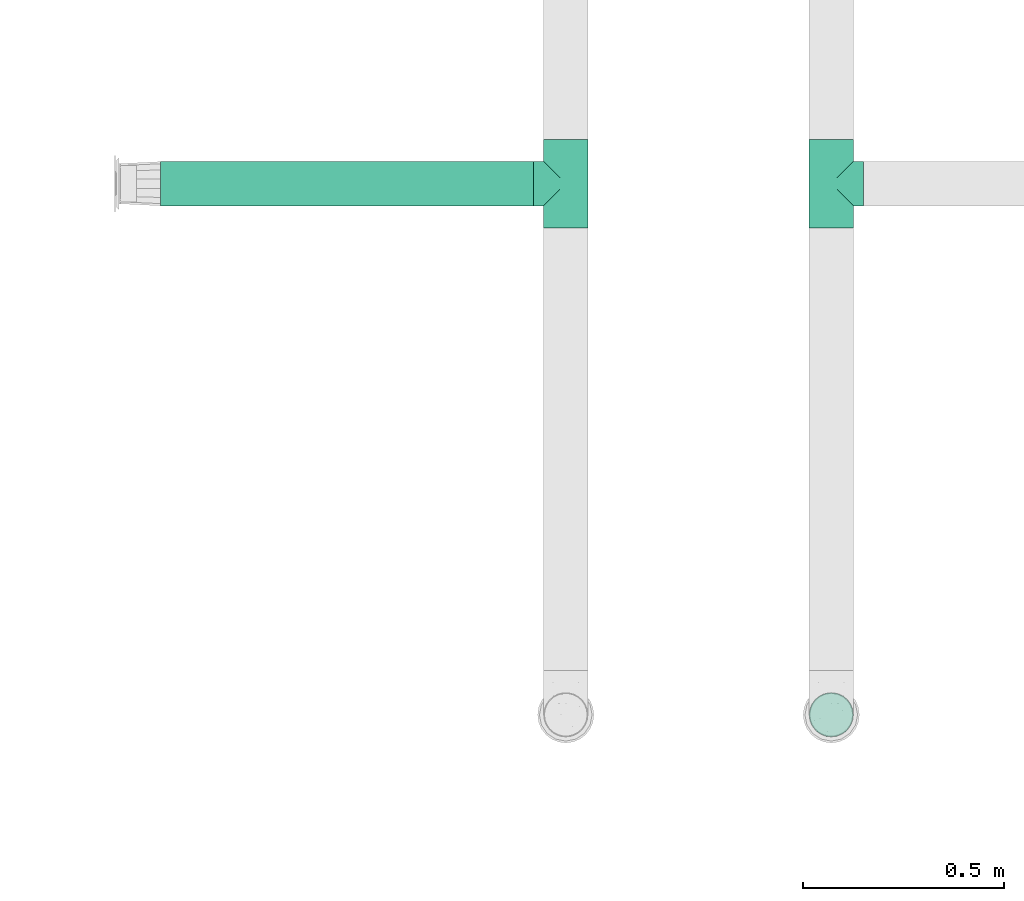
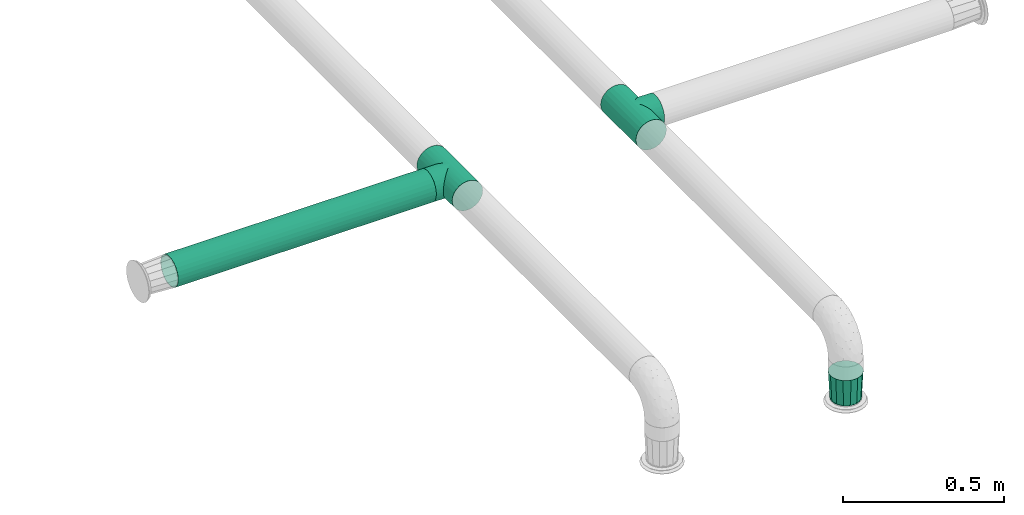
# One storey, part 50 of 115: 3 flow fittings, 1 flow segment.
"""IFC2X3 building model written with IfcOpenShell, lengths in millimetres."""

from ifc_helpers import new_model, entity, si_unit, converted_unit, derived_unit, direction, frame, origin_with_axes, origin_2d_with_axis, place, context, subcontext, project, spatial, hollow_circle, extrude, open_shell, surface_model, source, transform, mapped, material, layer, layer_set, layer_usage, type_object, element, save


model = new_model("IFC2X3")

# Units and contexts
model_context = context("Model", 3, precision=1e-05, world=origin_with_axes(), true_north=direction((0.0, 1.0)))
body_context = subcontext(model_context, "Body", "Model", "MODEL_VIEW")
ifc_project = project(units=[si_unit("AREAUNIT", "SQUARE_METRE"), si_unit("VOLUMEUNIT", "CUBIC_METRE", prefix="DECI"), si_unit("TIMEUNIT", "SECOND"), si_unit("THERMODYNAMICTEMPERATUREUNIT", "DEGREE_CELSIUS"), si_unit("PRESSUREUNIT", "PASCAL"), si_unit("MASSUNIT", "GRAM", prefix="KILO"), si_unit("LENGTHUNIT", "METRE", prefix="MILLI"), si_unit("POWERUNIT", "WATT"), si_unit("ELECTRICCURRENTUNIT", "AMPERE"), si_unit("ELECTRICVOLTAGEUNIT", "VOLT"), derived_unit("VOLUMETRICFLOWRATEUNIT", [(si_unit("VOLUMEUNIT", "CUBIC_METRE", prefix="DECI"), 1), (si_unit("TIMEUNIT", "SECOND"), -1)]), derived_unit("LINEARVELOCITYUNIT", [(si_unit("LENGTHUNIT", "METRE"), 1), (si_unit("TIMEUNIT", "SECOND"), -1)]), derived_unit("MASSDENSITYUNIT", [(si_unit("MASSUNIT", "GRAM", prefix="KILO"), 1), (si_unit("VOLUMEUNIT", "CUBIC_METRE"), -1)]), converted_unit("PLANEANGLEUNIT", "DEGREE", entity("IfcRatioMeasure", 0.01745), si_unit("PLANEANGLEUNIT", "RADIAN"), dimensions=[0, 0, 0, 0, 0, 0, 0])], contexts=[model_context])

# Site, building, storey
site_placement = place(None, origin_with_axes())
site = spatial("IfcSite", under=ifc_project, at=site_placement, CompositionType="ELEMENT")
building_placement = place(site_placement, origin_with_axes())
building = spatial("IfcBuilding", under=site, at=building_placement, Name="mc-building", CompositionType="ELEMENT")
storey_placement = place(building_placement, frame((0.0, 0.0, 2950.0), z_axis=(0.0, 0.0, 1.0), x_axis=(1.0, 0.0, 0.0)))
storey = spatial("IfcBuildingStorey", under=building, at=storey_placement, Name="2. Korrus", CompositionType="ELEMENT", Elevation=2950.0)

# Flow fittings
duct_fitting_type_1 = type_object("IfcDuctFittingType", PredefinedType="JUNCTION")
shared_shape_1 = source(origin_with_axes(), body_context, "Body", "SurfaceModel", [
    surface_model("IfcShellBasedSurfaceModel", [(0.0, -80.0, -55.0), (14.23505, -80.0, -53.12592), (-14.23505, -80.0, -53.12592), (-53.12592, -80.0, 14.23505), (-27.5, -80.0, -47.63139), (-47.63139, -80.0, -27.5), (-38.89087, -80.0, -38.89087), (55.0, -80.0, 0.0), (53.12592, -80.0, 14.23505), (38.89087, -80.0, -38.89087), (27.5, -80.0, -47.63139), (53.12592, -80.0, -14.23505), (47.63139, -80.0, -27.5), (-53.12592, -80.0, -14.23505), (-47.63139, -80.0, 27.5), (-38.89087, -80.0, 38.89087), (14.23505, -80.0, 53.12592), (-27.5, -80.0, 47.63139), (-14.23505, -80.0, 53.12592), (47.63139, -80.0, 27.5), (38.89087, -80.0, 38.89087), (27.5, -80.0, 47.63139), (0.0, -80.0, 55.0), (-55.0, -80.0, 0.0), (0.0, 0.0, 55.0), (-7.4066, -7.4066, 54.49901), (-14.74521, -14.74521, 52.98659), (-21.93978, -21.93978, 50.43457), (-28.89905, -28.89905, 46.79578), (-35.50357, -35.50357, 42.00591), (-41.58668, -41.58668, 35.99373), (-46.92319, -46.92319, 28.69171), (-51.19777, -51.19777, 20.0945), (-50.37866, -80.0, 20.86752), (-54.01174, -54.01174, 10.37938), (-55.0, -55.0, 0.0), (-54.06296, -80.0, 7.11752), (-54.01174, -54.01174, -10.37938), (-51.19777, -51.19777, -20.0945), (-54.06296, -80.0, -7.11752), (-46.92319, -46.92319, -28.69171), (-41.58668, -41.58668, -35.99373), (-50.37866, -80.0, -20.86752), (-35.50357, -35.50357, -42.00591), (-21.93978, -21.93978, -50.43457), (-14.74521, -14.74521, -52.98659), (-7.4066, -7.4066, -54.49901), (0.0, 0.0, -55.0), (-28.89905, -28.89905, -46.79578), (7.4066, -7.4066, -54.49901), (14.74521, -14.74521, -52.98659), (21.93978, -21.93978, -50.43457), (28.89905, -28.89905, -46.79578), (35.50357, -35.50357, -42.00591), (41.58668, -41.58668, -35.99373), (46.92319, -46.92319, -28.69171), (51.19777, -51.19777, -20.0945), (50.37866, -80.0, -20.86752), (54.01174, -54.01174, -10.37938), (55.0, -55.0, 0.0), (54.06296, -80.0, -7.11752), (54.01174, -54.01174, 10.37938), (51.19777, -51.19777, 20.0945), (54.06296, -80.0, 7.11752), (46.92319, -46.92319, 28.69171), (41.58668, -41.58668, 35.99373), (50.37866, -80.0, 20.86752), (35.50357, -35.50357, 42.00591), (21.93978, -21.93978, 50.43457), (14.74521, -14.74521, 52.98659), (7.4066, -7.4066, 54.49901), (28.89905, -28.89905, 46.79578), (-110.0, 0.0, -55.0), (-110.0, -14.23505, -53.12592), (-110.0, 14.23505, -53.12592), (-110.0, 53.12592, 14.23505), (-110.0, 27.5, -47.63139), (-110.0, 47.63139, -27.5), (-110.0, 38.89087, -38.89087), (-110.0, -55.0, 0.0), (-110.0, -53.12592, 14.23505), (-110.0, -38.89087, -38.89087), (-110.0, -27.5, -47.63139), (-110.0, -53.12592, -14.23505), (-110.0, -47.63139, -27.5), (-110.0, 53.12592, -14.23505), (-110.0, 47.63139, 27.5), (-110.0, 38.89087, 38.89087), (-110.0, -14.23505, 53.12592), (-110.0, 27.5, 47.63139), (-110.0, 14.23505, 53.12592), (-110.0, -47.63139, 27.5), (-110.0, -38.89087, 38.89087), (-110.0, -27.5, 47.63139), (-110.0, 0.0, 55.0), (-110.0, 55.0, 0.0), (110.0, 55.0, 0.0), (110.0, 0.0, -55.0), (110.0, 14.23505, -53.12592), (110.0, 27.5, -47.63139), (110.0, 38.89087, -38.89087), (110.0, 47.63139, -27.5), (110.0, -38.89087, -38.89087), (110.0, -53.12592, 14.23505), (110.0, -27.5, -47.63139), (110.0, -14.23505, -53.12592), (110.0, -47.63139, -27.5), (110.0, -53.12592, -14.23505), (110.0, -55.0, 0.0), (110.0, 53.12592, -14.23505), (110.0, 53.12592, 14.23505), (110.0, 47.63139, 27.5), (110.0, 38.89087, 38.89087), (110.0, 0.0, 55.0), (110.0, 27.5, 47.63139), (110.0, 14.23505, 53.12592), (110.0, -47.63139, 27.5), (110.0, -38.89087, 38.89087), (110.0, -27.5, 47.63139), (110.0, -14.23505, 53.12592)], [open_shell([[[0, 1, 2]], [[2, 3, 4]], [[5, 6, 3]], [[6, 4, 3]], [[2, 7, 8]], [[9, 7, 10]], [[1, 10, 7]], [[11, 7, 12]], [[9, 12, 7]], [[7, 2, 1]], [[5, 3, 13]], [[2, 14, 3]], [[2, 15, 14]], [[2, 16, 17]], [[17, 15, 2]], [[16, 18, 17]], [[2, 8, 19]], [[2, 19, 20]], [[2, 20, 21]], [[16, 2, 21]], [[16, 22, 18]], [[23, 13, 3]], [[24, 25, 22]], [[26, 27, 18]], [[25, 26, 18]], [[22, 25, 18]], [[17, 28, 29]], [[17, 18, 27]], [[17, 29, 15]], [[28, 17, 27]], [[30, 31, 14]], [[32, 3, 33]], [[32, 34, 3]], [[35, 36, 34]], [[31, 32, 14]], [[15, 30, 14]], [[34, 36, 3]], [[33, 14, 32]], [[36, 35, 23]], [[30, 15, 29]], [[37, 38, 13]], [[37, 13, 39]], [[40, 41, 5]], [[38, 5, 42]], [[38, 40, 5]], [[37, 39, 35]], [[35, 39, 23]], [[13, 38, 42]], [[41, 6, 5]], [[41, 43, 6]], [[44, 45, 2]], [[46, 47, 0]], [[45, 46, 2]], [[43, 48, 4]], [[44, 4, 48]], [[44, 2, 4]], [[46, 0, 2]], [[43, 4, 6]], [[47, 49, 0]], [[50, 51, 1]], [[49, 50, 1]], [[0, 49, 1]], [[10, 52, 53]], [[10, 1, 51]], [[10, 53, 9]], [[52, 10, 51]], [[54, 55, 12]], [[56, 11, 57]], [[56, 58, 11]], [[59, 60, 58]], [[55, 56, 12]], [[9, 54, 12]], [[58, 60, 11]], [[57, 12, 56]], [[60, 59, 7]], [[54, 9, 53]], [[61, 62, 8]], [[61, 8, 63]], [[64, 65, 19]], [[62, 19, 66]], [[62, 64, 19]], [[61, 63, 59]], [[7, 59, 63]], [[62, 66, 8]], [[65, 20, 19]], [[65, 67, 20]], [[68, 69, 16]], [[70, 24, 22]], [[69, 70, 16]], [[67, 71, 21]], [[68, 21, 71]], [[68, 16, 21]], [[70, 22, 16]], [[67, 21, 20]], [[72, 73, 74]], [[74, 75, 76]], [[77, 78, 75]], [[76, 75, 78]], [[74, 79, 80]], [[81, 79, 82]], [[73, 82, 79]], [[83, 79, 84]], [[81, 84, 79]], [[79, 74, 73]], [[77, 75, 85]], [[74, 86, 75]], [[74, 87, 86]], [[74, 88, 89]], [[89, 87, 74]], [[88, 90, 89]], [[74, 91, 92]], [[91, 74, 80]], [[92, 93, 74]], [[74, 93, 88]], [[88, 94, 90]], [[95, 85, 75]], [[96, 97, 98]], [[99, 96, 98]], [[96, 100, 101]], [[100, 96, 99]], [[102, 97, 103]], [[97, 102, 104]], [[104, 105, 97]], [[102, 103, 106]], [[106, 103, 107]], [[108, 107, 103]], [[109, 96, 101]], [[110, 111, 97]], [[97, 111, 112]], [[113, 97, 114]], [[97, 112, 114]], [[113, 114, 115]], [[116, 103, 97]], [[117, 116, 97]], [[118, 117, 97]], [[119, 118, 97]], [[119, 97, 113]], [[96, 110, 97]], [[24, 113, 115]], [[89, 115, 114]], [[94, 24, 90]], [[90, 24, 115]], [[115, 89, 90]], [[114, 87, 89]], [[86, 112, 111]], [[75, 111, 110]], [[95, 110, 96]], [[87, 112, 86]], [[86, 111, 75]], [[110, 95, 75]], [[112, 87, 114]], [[85, 96, 109]], [[77, 109, 101]], [[95, 96, 85]], [[85, 109, 77]], [[101, 78, 77]], [[101, 100, 78]], [[76, 100, 99]], [[74, 99, 98]], [[47, 98, 97]], [[76, 99, 74]], [[47, 72, 74]], [[98, 47, 74]], [[100, 76, 78]], [[47, 46, 72]], [[45, 44, 73]], [[46, 45, 73]], [[72, 46, 73]], [[82, 48, 43]], [[82, 73, 44]], [[82, 43, 81]], [[48, 82, 44]], [[41, 40, 84]], [[38, 37, 83]], [[40, 38, 84]], [[81, 41, 84]], [[37, 79, 83]], [[83, 84, 38]], [[79, 37, 35]], [[41, 81, 43]], [[49, 97, 105]], [[105, 104, 51]], [[53, 104, 102]], [[53, 52, 104]], [[49, 47, 97]], [[51, 50, 105]], [[52, 51, 104]], [[49, 105, 50]], [[54, 102, 106]], [[56, 106, 107]], [[58, 107, 108]], [[55, 54, 106]], [[58, 56, 107]], [[59, 58, 108]], [[55, 106, 56]], [[102, 54, 53]], [[34, 32, 80]], [[31, 30, 91]], [[32, 31, 91]], [[35, 34, 79]], [[80, 79, 34]], [[32, 91, 80]], [[30, 92, 91]], [[30, 29, 92]], [[27, 26, 88]], [[25, 24, 94]], [[26, 25, 88]], [[29, 28, 93]], [[27, 93, 28]], [[27, 88, 93]], [[25, 94, 88]], [[29, 93, 92]], [[61, 108, 103]], [[62, 103, 116]], [[65, 116, 117]], [[61, 59, 108]], [[64, 62, 116]], [[65, 64, 116]], [[61, 103, 62]], [[117, 67, 65]], [[71, 67, 118]], [[118, 67, 117]], [[68, 118, 119]], [[70, 119, 113]], [[68, 71, 118]], [[70, 69, 119]], [[24, 70, 113]], [[68, 119, 69]]])]),
])
flow_fitting_1_placement = place(storey_placement, frame((11458.64544, 9505.0, 2465.0), z_axis=(0.0, 0.0, 1.0), x_axis=(0.0, -1.0, 0.0)))
element("IfcFlowFitting", 1, at=flow_fitting_1_placement, inside=storey, type_object=duct_fitting_type_1, context=body_context, shape_type="MappedRepresentation", body=[
    mapped(shared_shape_1, transform((0.0, 0.0, 0.0), scale=1.0)),
])
duct_fitting_type_2 = type_object("IfcDuctFittingType", PredefinedType="TRANSITION")
shared_shape_2 = source(origin_with_axes(), body_context, "Body", "SurfaceModel", [
    surface_model("IfcShellBasedSurfaceModel", [(100.0, -55.0, 0.0), (100.0, -12.23865, 53.62104), (100.0, -34.29194, 43.00073), (100.0, 49.55329, 23.86361), (100.0, 34.29194, 43.00073), (100.0, 49.55329, -23.86361), (0.0, -45.04844, -21.69419), (0.0, -50.0, 0.0), (0.0, -45.04844, 21.69419), (0.0, 31.17449, 39.09157), (0.0, 45.04844, 21.69419), (0.0, 50.0, 0.0), (98.0, 47.63139, 27.5), (98.0, 0.0, 55.0), (98.0, 38.89087, 38.89087), (98.0, -38.89087, 38.89087), (98.0, -47.63139, 27.5), (100.0, 12.23865, 53.62104), (100.0, -49.55329, 23.86361), (100.0, 55.0, 0.0), (100.0, 12.23865, -53.62104), (100.0, 34.29194, -43.00073), (100.0, -49.55329, -23.86361), (100.0, -34.29194, -43.00073), (100.0, -12.23865, -53.62104), (0.0, -31.17449, 39.09157), (0.0, -11.12605, 48.7464), (0.0, 11.12605, 48.7464), (0.0, -31.17449, -39.09157), (0.0, 11.12605, -48.7464), (0.0, -11.12605, -48.7464), (0.0, 45.04844, -21.69419), (0.0, 31.17449, -39.09157), (0.0, 47.52422, -10.84709), (0.0, 38.11147, -30.39288), (100.0, 41.92261, -33.43217), (100.0, -41.92261, -33.43217), (0.0, -38.11147, -30.39288), (100.0, 23.2653, -48.31088), (0.0, 21.15027, -43.91899), (100.0, 52.32388, -11.72483), (0.0, 0.0, -48.7464), (100.0, 0.0, -53.62104), (0.0, -21.15027, -43.91899), (100.0, -23.2653, -48.31088), (0.0, -47.52422, -10.84709), (100.0, -52.32388, -11.72483), (0.0, -47.52422, 10.84709), (0.0, -38.11147, 30.39288), (100.0, -41.92261, 33.43217), (100.0, 41.92261, 33.43217), (0.0, 38.11147, 30.39288), (100.0, -23.2653, 48.31088), (0.0, -21.15027, 43.91899), (100.0, -52.32388, 11.72483), (0.0, 0.0, 48.7464), (100.0, 0.0, 53.62104), (0.0, 21.15027, 43.91899), (100.0, 23.2653, 48.31088), (0.0, 47.52422, 10.84709), (100.0, 52.32388, 11.72483), (100.0, -14.23505, -53.12592), (100.0, 0.0, -55.0), (100.0, -27.5, -47.63139), (100.0, 27.5, -47.63139), (100.0, -38.89087, -38.89087), (100.0, -53.12592, -14.23505), (100.0, -47.63139, -27.5), (100.0, -47.63139, 27.5), (100.0, 14.23505, -53.12592), (100.0, 38.89087, -38.89087), (100.0, 47.63139, -27.5), (100.0, 47.63139, 27.5), (100.0, 53.12592, -14.23505), (100.0, -53.12592, 14.23505), (100.0, -38.89087, 38.89087), (100.0, -27.5, 47.63139), (100.0, 0.0, 55.0), (100.0, -14.23505, 53.12592), (100.0, 53.12592, 14.23505), (100.0, 38.89087, 38.89087), (100.0, 27.5, 47.63139), (100.0, 14.23505, 53.12592), (98.0, -27.5, 47.63139), (98.0, -14.23505, 53.12592), (98.0, -53.12592, -14.23505), (98.0, 14.23505, 53.12592), (98.0, 27.5, 47.63139), (98.0, 53.12592, 14.23505), (98.0, 55.0, 0.0), (98.0, -47.63139, -27.5), (98.0, -53.12592, 14.23505), (98.0, 27.5, -47.63139), (98.0, -27.5, -47.63139), (98.0, -38.89087, -38.89087), (98.0, 0.0, -55.0), (98.0, -14.23505, -53.12592), (98.0, 38.89087, -38.89087), (98.0, 47.63139, -27.5), (98.0, 53.12592, -14.23505), (98.0, 14.23505, -53.12592), (98.0, -55.0, 0.0), (0.0, 0.0, 50.0), (0.0, 35.35534, 35.35534), (0.0, -12.94095, 48.29629), (0.0, -25.0, 43.30127), (0.0, -35.35534, 35.35534), (0.0, -48.29629, 12.94095), (0.0, -43.30127, 25.0), (0.0, 25.0, 43.30127), (0.0, 12.94095, 48.29629), (0.0, 43.30127, 25.0), (0.0, 48.29629, 12.94095), (0.0, 25.0, -43.30127), (0.0, 48.29629, -12.94095), (0.0, -48.29629, -12.94095), (0.0, -43.30127, -25.0), (0.0, -12.94095, -48.29629), (0.0, -25.0, -43.30127), (0.0, -35.35534, -35.35534), (0.0, 43.30127, -25.0), (0.0, 35.35534, -35.35534), (0.0, 12.94095, -48.29629), (0.0, 0.0, -50.0), (2.0, -35.35534, -35.35534), (2.0, -25.0, -43.30127), (2.0, -12.94095, -48.29629), (2.0, -43.30127, -25.0), (2.0, 0.0, -50.0), (2.0, -48.29629, -12.94095), (2.0, -50.0, 0.0), (2.0, 12.94095, -48.29629), (2.0, 25.0, -43.30127), (2.0, 43.30127, -25.0), (2.0, 48.29629, -12.94095), (2.0, 35.35534, -35.35534), (2.0, -48.29629, 12.94095), (2.0, -35.35534, 35.35534), (2.0, -43.30127, 25.0), (2.0, 35.35534, 35.35534), (2.0, -12.94095, 48.29629), (2.0, -25.0, 43.30127), (2.0, 0.0, 50.0), (2.0, 43.30127, 25.0), (2.0, 48.29629, 12.94095), (2.0, 50.0, 0.0), (2.0, 25.0, 43.30127), (2.0, 12.94095, 48.29629)], [open_shell([[[0, 1, 2]], [[3, 4, 5]], [[6, 7, 8]], [[9, 10, 11]], [[12, 13, 14]], [[15, 13, 16]], [[0, 4, 17]], [[2, 18, 0]], [[1, 0, 17]], [[3, 5, 19]], [[20, 21, 5]], [[22, 20, 5]], [[22, 5, 0]], [[22, 23, 24]], [[22, 24, 20]], [[4, 0, 5]], [[8, 25, 6]], [[6, 25, 26]], [[6, 26, 27]], [[11, 27, 9]], [[28, 6, 29]], [[30, 28, 29]], [[31, 6, 11]], [[31, 32, 29]], [[31, 29, 6]], [[27, 11, 6]], [[31, 33, 5]], [[34, 35, 32]], [[36, 22, 6]], [[36, 37, 23]], [[38, 29, 39]], [[33, 40, 5]], [[33, 11, 40]], [[19, 40, 11]], [[32, 21, 39]], [[32, 35, 21]], [[34, 31, 35]], [[30, 41, 42]], [[28, 43, 44]], [[42, 41, 20]], [[7, 45, 46]], [[38, 39, 21]], [[46, 0, 7]], [[6, 37, 36]], [[38, 20, 29]], [[43, 30, 24]], [[42, 24, 30]], [[28, 23, 37]], [[6, 22, 45]], [[35, 31, 5]], [[44, 43, 24]], [[20, 41, 29]], [[46, 45, 22]], [[44, 23, 28]], [[8, 47, 18]], [[48, 49, 25]], [[50, 3, 10]], [[50, 51, 4]], [[52, 26, 53]], [[47, 54, 18]], [[47, 7, 54]], [[0, 54, 7]], [[25, 2, 53]], [[25, 49, 2]], [[48, 8, 49]], [[27, 55, 56]], [[9, 57, 58]], [[56, 55, 1]], [[11, 59, 60]], [[52, 53, 2]], [[60, 19, 11]], [[10, 51, 50]], [[52, 1, 26]], [[57, 27, 17]], [[56, 17, 27]], [[9, 4, 51]], [[10, 3, 59]], [[49, 8, 18]], [[58, 57, 17]], [[1, 55, 26]], [[60, 59, 3]], [[58, 4, 9]], [[61, 62, 63]], [[63, 64, 65]], [[66, 67, 68]], [[65, 64, 67]], [[67, 64, 68]], [[69, 64, 62]], [[64, 63, 62]], [[70, 71, 64]], [[72, 64, 71]], [[71, 73, 19]], [[74, 0, 66]], [[72, 68, 64]], [[75, 68, 76]], [[77, 78, 76]], [[72, 76, 68]], [[76, 72, 77]], [[79, 72, 19]], [[19, 72, 71]], [[80, 81, 77]], [[77, 72, 80]], [[82, 77, 81]], [[74, 66, 68]], [[83, 84, 13]], [[15, 83, 13]], [[12, 16, 13]], [[16, 12, 85]], [[86, 87, 13]], [[87, 14, 13]], [[88, 89, 12]], [[89, 90, 12]], [[91, 16, 85]], [[90, 85, 12]], [[89, 92, 90]], [[93, 94, 95]], [[95, 94, 90]], [[96, 93, 95]], [[97, 92, 98]], [[98, 89, 99]], [[100, 95, 92]], [[92, 89, 98]], [[90, 92, 95]], [[101, 91, 85]], [[89, 73, 99]], [[99, 71, 98]], [[92, 97, 64]], [[70, 97, 98]], [[100, 92, 69]], [[73, 71, 99]], [[89, 19, 73]], [[92, 64, 69]], [[64, 97, 70]], [[98, 71, 70]], [[100, 69, 62]], [[62, 95, 100]], [[95, 61, 96]], [[96, 63, 93]], [[90, 94, 67]], [[65, 94, 93]], [[85, 90, 66]], [[63, 65, 93]], [[96, 61, 63]], [[85, 66, 0]], [[66, 90, 67]], [[94, 65, 67]], [[85, 0, 101]], [[62, 61, 95]], [[101, 74, 91]], [[91, 68, 16]], [[83, 15, 76]], [[75, 15, 16]], [[84, 83, 78]], [[74, 68, 91]], [[101, 0, 74]], [[83, 76, 78]], [[76, 15, 75]], [[16, 68, 75]], [[84, 78, 77]], [[77, 13, 84]], [[13, 82, 86]], [[86, 81, 87]], [[12, 14, 72]], [[80, 14, 87]], [[88, 12, 79]], [[81, 80, 87]], [[86, 82, 81]], [[88, 79, 19]], [[79, 12, 72]], [[14, 80, 72]], [[88, 19, 89]], [[77, 82, 13]], [[102, 103, 104]], [[105, 104, 106]], [[107, 108, 106]], [[103, 106, 104]], [[106, 103, 107]], [[109, 103, 110]], [[103, 102, 110]], [[111, 112, 103]], [[113, 103, 112]], [[112, 11, 114]], [[107, 103, 113]], [[113, 115, 107]], [[116, 115, 117]], [[117, 118, 119]], [[116, 117, 119]], [[117, 115, 113]], [[120, 121, 114]], [[113, 114, 121]], [[113, 122, 117]], [[113, 112, 114]], [[117, 122, 123]], [[7, 107, 115]], [[124, 125, 126]], [[127, 124, 126]], [[128, 129, 126]], [[127, 126, 129]], [[130, 129, 128]], [[131, 132, 128]], [[132, 130, 128]], [[133, 134, 135]], [[132, 135, 134]], [[132, 134, 130]], [[134, 136, 130]], [[137, 138, 136]], [[137, 136, 139]], [[140, 137, 139]], [[141, 137, 140]], [[142, 140, 139]], [[143, 139, 144]], [[144, 134, 145]], [[146, 147, 139]], [[139, 136, 144]], [[139, 147, 142]], [[136, 134, 144]], [[11, 134, 114]], [[114, 133, 120]], [[113, 121, 132]], [[135, 121, 120]], [[122, 113, 131]], [[134, 133, 114]], [[11, 145, 134]], [[113, 132, 131]], [[132, 121, 135]], [[120, 133, 135]], [[122, 131, 128]], [[128, 123, 122]], [[123, 126, 117]], [[117, 125, 118]], [[116, 119, 127]], [[124, 119, 118]], [[115, 116, 129]], [[125, 124, 118]], [[117, 126, 125]], [[115, 129, 130]], [[129, 116, 127]], [[119, 124, 127]], [[115, 130, 7]], [[128, 126, 123]], [[7, 136, 107]], [[107, 138, 108]], [[105, 106, 141]], [[137, 106, 108]], [[104, 105, 140]], [[136, 138, 107]], [[7, 130, 136]], [[105, 141, 140]], [[141, 106, 137]], [[108, 138, 137]], [[104, 140, 142]], [[142, 102, 104]], [[102, 147, 110]], [[110, 146, 109]], [[111, 103, 143]], [[139, 103, 109]], [[112, 111, 144]], [[146, 139, 109]], [[110, 147, 146]], [[112, 144, 145]], [[144, 111, 143]], [[103, 139, 143]], [[112, 145, 11]], [[142, 147, 102]]])]),
])
flow_fitting_2_placement = place(storey_placement, frame((12119.2372, 8183.57591, 2203.1), z_axis=(0.0, 1.0, 0.0), x_axis=(0.0, 0.0, 1.0)))
element("IfcFlowFitting", 2, at=flow_fitting_2_placement, inside=storey, type_object=duct_fitting_type_2, context=body_context, shape_type="MappedRepresentation", body=[
    mapped(shared_shape_2, transform((0.0, 0.0, 0.0), scale=1.0)),
])
shared_shape_3 = source(origin_with_axes(), body_context, "Body", "SurfaceModel", [
    surface_model("IfcShellBasedSurfaceModel", [(-110.0, -38.89087, -38.89087), (-110.0, -55.0, 0.0), (-110.0, -27.5, -47.63139), (-110.0, -53.12592, -14.23505), (-110.0, -47.63139, -27.5), (-110.0, 47.63139, -27.5), (-110.0, 53.12592, 14.23505), (-110.0, 53.12592, -14.23505), (-110.0, 55.0, 0.0), (110.0, 38.89087, -38.89087), (110.0, 55.0, 0.0), (110.0, 27.5, -47.63139), (110.0, -38.89087, -38.89087), (110.0, -53.12592, 14.23505), (110.0, -47.63139, -27.5), (110.0, -55.0, 0.0), (110.0, -53.12592, -14.23505), (110.0, 53.12592, -14.23505), (110.0, 47.63139, -27.5), (-110.0, 38.89087, -38.89087), (-110.0, -14.23505, -53.12592), (-110.0, 0.0, -55.0), (-110.0, 27.5, -47.63139), (-110.0, 14.23505, -53.12592), (-110.0, -53.12592, 14.23505), (-110.0, -47.63139, 27.5), (-110.0, -38.89087, 38.89087), (-110.0, 14.23505, 53.12592), (-110.0, 27.5, 47.63139), (-55.0, 80.0, 0.0), (0.0, 80.0, -55.0), (-14.23505, 80.0, -53.12592), (-27.5, 80.0, -47.63139), (-38.89087, 80.0, -38.89087), (-47.63139, 80.0, -27.5), (38.89087, 80.0, -38.89087), (53.12592, 80.0, 14.23505), (27.5, 80.0, -47.63139), (14.23505, 80.0, -53.12592), (47.63139, 80.0, -27.5), (53.12592, 80.0, -14.23505), (55.0, 80.0, 0.0), (-53.12592, 80.0, -14.23505), (-53.12592, 80.0, 14.23505), (-47.63139, 80.0, 27.5), (-38.89087, 80.0, 38.89087), (0.0, 80.0, 55.0), (-27.5, 80.0, 47.63139), (-14.23505, 80.0, 53.12592), (47.63139, 80.0, 27.5), (38.89087, 80.0, 38.89087), (27.5, 80.0, 47.63139), (14.23505, 80.0, 53.12592), (-7.4066, 7.4066, 54.49901), (0.0, 0.0, 55.0), (-21.93978, 21.93978, 50.43457), (-14.74521, 14.74521, 52.98659), (-35.50357, 35.50357, 42.00591), (-28.89905, 28.89905, 46.79578), (-46.92319, 46.92319, 28.69171), (-41.58668, 41.58668, 35.99373), (-54.01174, 54.01174, 10.37938), (-54.06296, 80.0, 7.11752), (-55.0, 55.0, 0.0), (-51.19777, 51.19777, 20.0945), (-50.37866, 80.0, 20.86752), (-51.19777, 51.19777, -20.0945), (-54.01174, 54.01174, -10.37938), (-50.37866, 80.0, -20.86752), (-41.58668, 41.58668, -35.99373), (-46.92319, 46.92319, -28.69171), (-54.06296, 80.0, -7.11752), (-35.50357, 35.50357, -42.00591), (-14.74521, 14.74521, -52.98659), (-21.93978, 21.93978, -50.43457), (0.0, 0.0, -55.0), (-7.4066, 7.4066, -54.49901), (-28.89905, 28.89905, -46.79578), (7.4066, 7.4066, -54.49901), (21.93978, 21.93978, -50.43457), (14.74521, 14.74521, -52.98659), (35.50357, 35.50357, -42.00591), (28.89905, 28.89905, -46.79578), (46.92319, 46.92319, -28.69171), (41.58668, 41.58668, -35.99373), (54.01174, 54.01174, -10.37938), (54.06296, 80.0, -7.11752), (55.0, 55.0, 0.0), (51.19777, 51.19777, -20.0945), (50.37866, 80.0, -20.86752), (51.19777, 51.19777, 20.0945), (54.01174, 54.01174, 10.37938), (50.37866, 80.0, 20.86752), (41.58668, 41.58668, 35.99373), (46.92319, 46.92319, 28.69171), (54.06296, 80.0, 7.11752), (35.50357, 35.50357, 42.00591), (14.74521, 14.74521, 52.98659), (21.93978, 21.93978, 50.43457), (7.4066, 7.4066, 54.49901), (28.89905, 28.89905, 46.79578), (-110.0, -27.5, 47.63139), (-110.0, 0.0, 55.0), (-110.0, -14.23505, 53.12592), (-110.0, 47.63139, 27.5), (-110.0, 38.89087, 38.89087), (110.0, 0.0, -55.0), (110.0, 14.23505, -53.12592), (110.0, -14.23505, -53.12592), (110.0, -27.5, -47.63139), (110.0, 53.12592, 14.23505), (110.0, -47.63139, 27.5), (110.0, -38.89087, 38.89087), (110.0, 14.23505, 53.12592), (110.0, -27.5, 47.63139), (110.0, -14.23505, 53.12592), (110.0, 47.63139, 27.5), (110.0, 38.89087, 38.89087), (110.0, 27.5, 47.63139), (110.0, 0.0, 55.0)], [open_shell([[[0, 1, 2]], [[3, 1, 4]], [[5, 6, 7]], [[8, 7, 6]], [[9, 10, 11]], [[12, 13, 14]], [[15, 16, 13]], [[17, 10, 18]], [[19, 6, 5]], [[2, 1, 20]], [[19, 21, 6]], [[21, 19, 22]], [[22, 23, 21]], [[24, 25, 21]], [[21, 25, 26]], [[27, 28, 21]], [[29, 30, 31]], [[32, 29, 31]], [[29, 33, 34]], [[29, 32, 33]], [[35, 30, 36]], [[30, 35, 37]], [[37, 38, 30]], [[35, 36, 39]], [[39, 36, 40]], [[41, 40, 36]], [[42, 29, 34]], [[43, 44, 30]], [[30, 44, 45]], [[46, 30, 47]], [[30, 45, 47]], [[46, 47, 48]], [[49, 36, 30]], [[50, 49, 30]], [[51, 50, 30]], [[52, 51, 30]], [[52, 30, 46]], [[29, 43, 30]], [[46, 53, 54]], [[48, 55, 56]], [[48, 56, 53]], [[48, 53, 46]], [[57, 58, 47]], [[55, 48, 47]], [[45, 57, 47]], [[55, 47, 58]], [[44, 59, 60]], [[61, 62, 63]], [[43, 61, 64]], [[65, 43, 64]], [[44, 64, 59]], [[44, 60, 45]], [[43, 62, 61]], [[64, 44, 65]], [[29, 63, 62]], [[57, 45, 60]], [[42, 66, 67]], [[68, 34, 66]], [[34, 69, 70]], [[71, 42, 67]], [[34, 70, 66]], [[63, 71, 67]], [[29, 71, 63]], [[68, 66, 42]], [[34, 33, 69]], [[33, 72, 69]], [[31, 73, 74]], [[30, 75, 76]], [[31, 76, 73]], [[32, 77, 72]], [[77, 32, 74]], [[32, 31, 74]], [[31, 30, 76]], [[33, 32, 72]], [[30, 78, 75]], [[38, 79, 80]], [[38, 80, 78]], [[38, 78, 30]], [[81, 82, 37]], [[79, 38, 37]], [[35, 81, 37]], [[79, 37, 82]], [[39, 83, 84]], [[85, 86, 87]], [[40, 85, 88]], [[89, 40, 88]], [[39, 88, 83]], [[39, 84, 35]], [[40, 86, 85]], [[88, 39, 89]], [[41, 87, 86]], [[81, 35, 84]], [[36, 90, 91]], [[92, 49, 90]], [[49, 93, 94]], [[95, 36, 91]], [[49, 94, 90]], [[87, 95, 91]], [[95, 87, 41]], [[36, 92, 90]], [[49, 50, 93]], [[50, 96, 93]], [[52, 97, 98]], [[46, 54, 99]], [[52, 99, 97]], [[51, 100, 96]], [[100, 51, 98]], [[51, 52, 98]], [[52, 46, 99]], [[50, 51, 96]], [[1, 21, 20]], [[1, 0, 4]], [[101, 102, 26]], [[102, 21, 26]], [[102, 101, 103]], [[104, 6, 21]], [[105, 104, 21]], [[105, 21, 28]], [[21, 102, 27]], [[1, 24, 21]], [[106, 107, 108]], [[108, 13, 109]], [[109, 13, 12]], [[108, 10, 110]], [[107, 11, 10]], [[9, 18, 10]], [[10, 108, 107]], [[16, 14, 13]], [[108, 111, 13]], [[108, 112, 111]], [[108, 113, 114]], [[114, 112, 108]], [[113, 115, 114]], [[108, 110, 116]], [[108, 116, 117]], [[108, 117, 118]], [[113, 108, 118]], [[113, 119, 115]], [[115, 119, 54]], [[114, 115, 101]], [[103, 54, 102]], [[115, 54, 103]], [[103, 101, 115]], [[101, 26, 114]], [[111, 112, 25]], [[13, 111, 24]], [[15, 13, 1]], [[25, 112, 26]], [[24, 111, 25]], [[24, 1, 13]], [[114, 26, 112]], [[16, 15, 3]], [[14, 16, 4]], [[3, 15, 1]], [[4, 16, 3]], [[4, 0, 14]], [[0, 12, 14]], [[109, 12, 2]], [[108, 109, 20]], [[106, 108, 75]], [[20, 109, 2]], [[20, 21, 75]], [[20, 75, 108]], [[0, 2, 12]], [[21, 76, 75]], [[23, 74, 73]], [[23, 73, 76]], [[23, 76, 21]], [[72, 77, 22]], [[74, 23, 22]], [[19, 72, 22]], [[74, 22, 77]], [[5, 70, 69]], [[7, 67, 66]], [[5, 66, 70]], [[5, 69, 19]], [[7, 8, 67]], [[66, 5, 7]], [[63, 67, 8]], [[72, 19, 69]], [[107, 106, 78]], [[79, 11, 107]], [[9, 11, 81]], [[11, 82, 81]], [[106, 75, 78]], [[107, 80, 79]], [[11, 79, 82]], [[80, 107, 78]], [[18, 9, 84]], [[17, 18, 88]], [[10, 17, 85]], [[18, 84, 83]], [[17, 88, 85]], [[10, 85, 87]], [[88, 18, 83]], [[81, 84, 9]], [[110, 10, 91]], [[116, 110, 90]], [[117, 116, 93]], [[10, 87, 91]], [[116, 90, 94]], [[116, 94, 93]], [[90, 110, 91]], [[93, 96, 117]], [[118, 96, 100]], [[117, 96, 118]], [[113, 118, 98]], [[119, 113, 99]], [[118, 100, 98]], [[113, 97, 99]], [[119, 99, 54]], [[97, 113, 98]], [[6, 64, 61]], [[104, 60, 59]], [[104, 59, 64]], [[8, 61, 63]], [[61, 8, 6]], [[6, 104, 64]], [[104, 105, 60]], [[105, 57, 60]], [[27, 56, 55]], [[102, 54, 53]], [[27, 53, 56]], [[28, 58, 57]], [[58, 28, 55]], [[28, 27, 55]], [[27, 102, 53]], [[105, 28, 57]]])]),
])
flow_fitting_3_placement = place(storey_placement, frame((12119.2372, 9505.0, 2465.0), z_axis=(0.0, 0.0, 1.0), x_axis=(0.0, -1.0, 0.0)))
element("IfcFlowFitting", 3, at=flow_fitting_3_placement, inside=storey, type_object=duct_fitting_type_1, context=body_context, shape_type="MappedRepresentation", body=[
    mapped(shared_shape_3, transform((0.0, 0.0, 0.0), scale=1.0)),
])

# Flow segment
ifc_material = material(Name="FZ1")
ifc_layer = layer(ifc_material, 0.0)
ifc_layer_set = layer_set([ifc_layer], Name="FZ1")
ifc_layer_usage = layer_usage(ifc_layer_set, "AXIS1", "POSITIVE", 0.0)
duct_segment_type = type_object("IfcDuctSegmentType", PredefinedType="RIGIDSEGMENT")
shared_shape_4 = source(origin_with_axes(), body_context, "Body", "SweptSolid", [
    extrude(hollow_circle(Radius=55.0, WallThickness=2.0, at=origin_2d_with_axis()), frame((0.0, 0.0, 0.0), z_axis=(1.0, 0.0, 0.0), x_axis=(0.0, 1.0, 0.0)), (0.0, 0.0, 1.0), 928.2),
])
flow_segment_placement = place(storey_placement, frame((11378.64544, 9505.0, 2465.0), z_axis=(0.0, 0.0, 1.0), x_axis=(-1.0, 0.0, 0.0)))
element("IfcFlowSegment", 4, at=flow_segment_placement, inside=storey, type_object=duct_segment_type, material=ifc_layer_usage, context=body_context, shape_type="MappedRepresentation", body=[
    mapped(shared_shape_4, transform((0.0, 0.0, 0.0), scale=1.0)),
])

save(model, "model.ifc")
